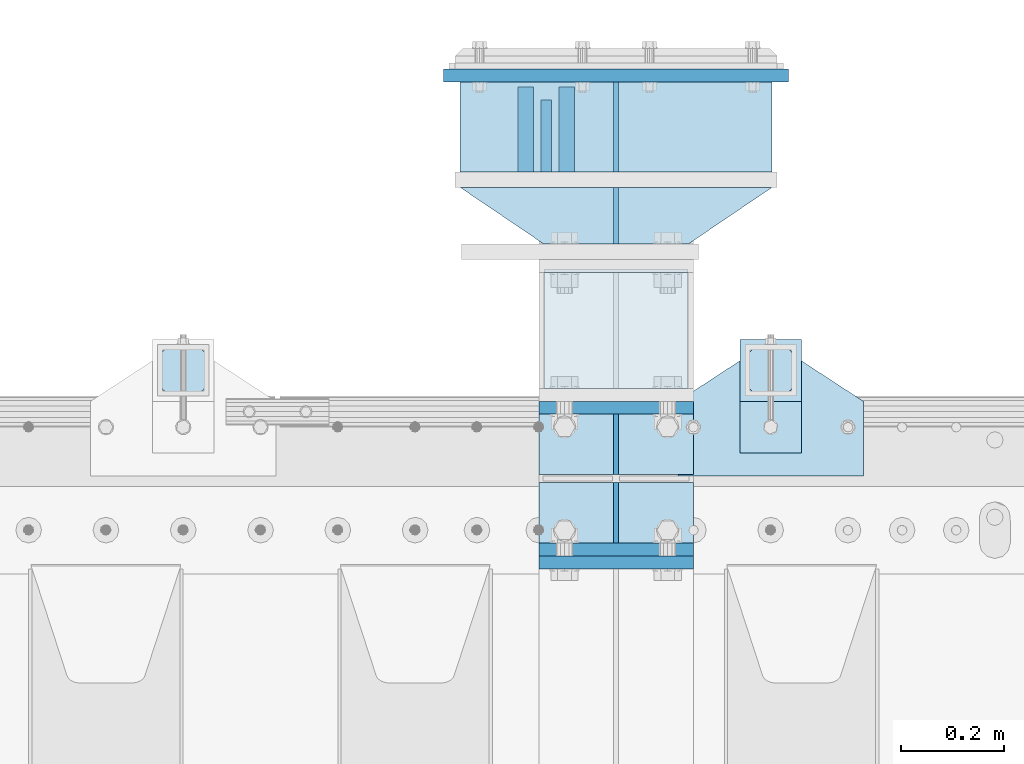
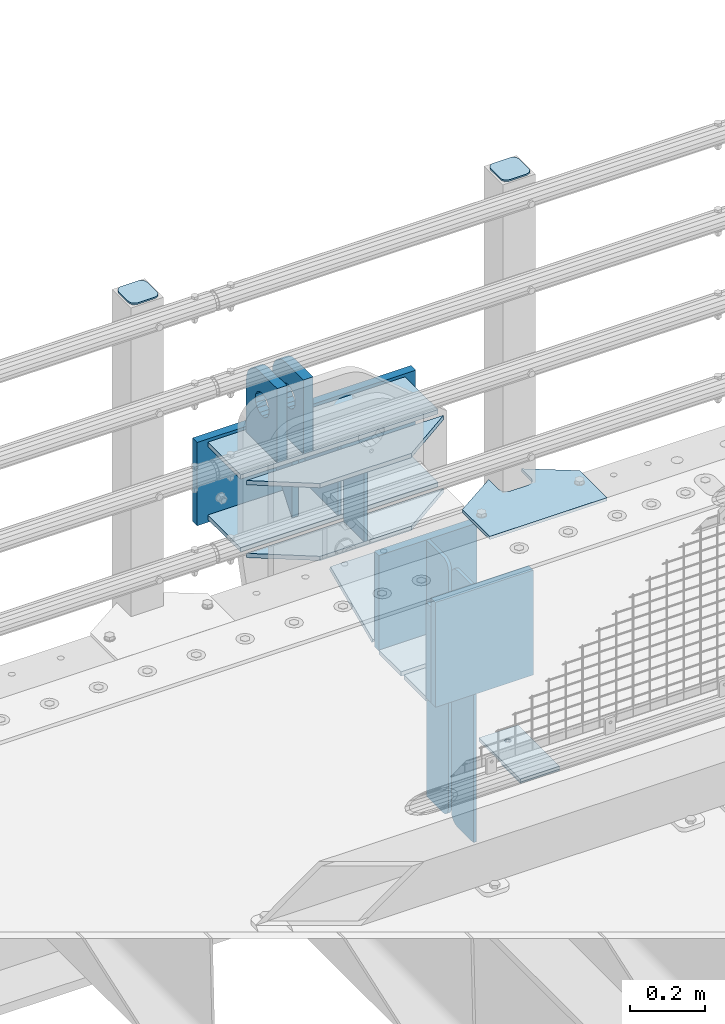
# One storey, part 225 of 240: 25 plates.
"""IFC2X3 building model written with IfcOpenShell, lengths in millimetres."""

from ifc_helpers import new_model, si_unit, frame, origin_with_axes, place, context, subcontext, project, spatial, faceted_brep, material, type_object, element, save


model = new_model("IFC2X3")

# Units and contexts
model_context = context("Model", 3, precision=1e-05, world=origin_with_axes())
body_context = subcontext(model_context, "Body", "Model", "MODEL_VIEW")
ifc_project = project(units=[si_unit("LENGTHUNIT", "METRE", prefix="MILLI"), si_unit("AREAUNIT", "SQUARE_METRE"), si_unit("VOLUMEUNIT", "CUBIC_METRE"), si_unit("MASSUNIT", "GRAM", prefix="KILO"), si_unit("TIMEUNIT", "SECOND"), si_unit("PLANEANGLEUNIT", "RADIAN"), si_unit("SOLIDANGLEUNIT", "STERADIAN"), si_unit("THERMODYNAMICTEMPERATUREUNIT", "DEGREE_CELSIUS"), si_unit("LUMINOUSINTENSITYUNIT", "LUMEN")], contexts=[model_context])

# Site, building, storey
site_placement = place(None, origin_with_axes())
site = spatial("IfcSite", under=ifc_project, at=site_placement, CompositionType="ELEMENT")
building_placement = place(site_placement, origin_with_axes())
building = spatial("IfcBuilding", under=site, at=building_placement, Name="Standard", CompositionType="ELEMENT")
storey_placement = place(building_placement, origin_with_axes())
storey = spatial("IfcBuildingStorey", under=building, at=storey_placement, Name="Undefined", CompositionType="ELEMENT", Elevation=0.0)

# Plates
ifc_material_1 = material(Name="STEEL/S355N")
plate_type_1 = type_object("IfcPlateType", PredefinedType="NOTDEFINED")
plate_1_placement = place(storey_placement, frame((52704.5000000536, 36735.0000000104, -14.000018238301), z_axis=(0.0, 0.0, -1.0), x_axis=(0.0, -1.0, 0.0)))
element("IfcPlate", 1, at=plate_1_placement, inside=storey, type_object=plate_type_1, material=ifc_material_1, context=body_context, shape_type="Brep", body=[
    faceted_brep([(0.0, -10.0, 0.0), (140.0, -10.0, 180.0), (140.0, 10.0, 180.0), (0.0, 10.0, 0.0), (140.0, -10.0, -1.81898940354586e-12), (140.0, 10.0, -1.81898940354586e-12)], [[[0, 1, 2, 3]], [[1, 4, 5, 2]], [[4, 0, 3, 5]], [[5, 3, 2]], [[4, 1, 0]]]),
])
plate_type_2 = type_object("IfcPlateType", PredefinedType="NOTDEFINED")
plate_2_placement = place(storey_placement, frame((52744.5000000519, 36595.0000000103, -1.8238333723275e-05), z_axis=(0.0, 1.0, 0.0), x_axis=(0.0, 0.0, 1.0)))
element("IfcPlate", 2, at=plate_2_placement, inside=storey, type_object=plate_type_2, material=ifc_material_1, context=body_context, shape_type="Brep", body=[
    faceted_brep([(125.840713002475, 15.0000005560505, 114.183542552877), (125.840713002475, -14.9999994439495, 114.183542852879), (113.837049096081, -14.9999995241524, 106.16295105387), (113.837049096081, 15.0000004758476, 106.162950753867), (105.816457297066, -14.9999996441911, 94.1592871474713), (105.816457297066, 15.0000003558089, 94.159286847469), (102.999999999984, -14.9999997857813, 80.0000001499648), (102.999999999984, 15.0000002142187, 79.9999998499625), (105.816457297066, -14.9999999273787, 65.8407131524582), (105.816457297066, 15.0000000726213, 65.8407128524559), (113.837049096081, -15.0000000474101, 53.8370492460599), (113.837049096081, 14.9999999525899, 53.8370489460576), (125.840713002475, -15.0000001276203, 45.8164574470502), (125.840713002475, 14.9999998723797, 45.8164571470479), (139.999999999984, -15.0000001557783, 43.0000001499648), (139.999999999984, 14.9999998442217, 42.9999998499625), (154.159286997492, -15.0000001276203, 45.8164574470502), (154.159286997492, 14.9999998723797, 45.8164571470479), (166.162950903886, -15.0000000474101, 53.8370492460599), (166.162950903886, 14.9999999525899, 53.8370489460576), (174.183542702901, -14.9999999273787, 65.8407131524582), (174.183542702901, 15.0000000726213, 65.8407128524559), (176.999999999984, -14.9999997857813, 80.0000001499648), (176.999999999984, 15.0000002142187, 79.9999998499625), (174.183542702901, -14.9999996441911, 94.1592871474713), (174.183542702901, 15.0000003558089, 94.159286847469), (166.162950903886, -14.9999995241524, 106.16295105387), (166.162950903886, 15.0000004758476, 106.162950753867), (154.159286997492, -14.9999994439495, 114.183542852879), (154.159286997492, 15.0000005560505, 114.183542552877), (139.999999999984, -14.9999994157915, 117.000000149965), (139.999999999984, 15.0000005842085, 116.999999849962), (-1.40620068123098e-06, -14.9999999999927, 165.000000000007), (170.002837349484, -14.9999999999927, 164.997157401471), (170.002837349484, 15.0000000000073, 164.997157401463), (-1.40620068123098e-06, 15.0000000000073, 165.0), (188.120138118986, -14.9999999999927, 162.611660295071), (188.120138118986, 15.0000000000073, 162.611660295064), (205.002693976271, -14.9999999999927, 155.618342674454), (205.002693976271, 15.0000000000073, 155.618342674454), (219.499985670386, -14.9999999999927, 144.493787979867), (219.499985670386, 15.0000000000073, 144.493787979867), (230.624045898169, -14.9999999999927, 129.996116868075), (230.624045898169, 15.0000000000073, 129.996116868067), (237.616787699976, -14.9999999999927, 113.113322498939), (237.616787699976, 15.0000000000073, 113.113322498939), (240.001666876698, -15.0, 94.9959403776302), (240.001666876698, 15.0, 94.9959403776229), (240.000015258789, -14.9999999999927, -2.03726813197136e-10), (240.000015258789, 15.0000000000073, -2.03726813197136e-10), (0.0, -15.0, 0.0), (0.0, 15.0, 0.0)], [[[0, 1, 2, 3]], [[3, 2, 4, 5]], [[5, 4, 6, 7]], [[7, 6, 8, 9]], [[9, 8, 10, 11]], [[11, 10, 12, 13]], [[13, 12, 14, 15]], [[15, 14, 16, 17]], [[17, 16, 18, 19]], [[19, 18, 20, 21]], [[21, 20, 22, 23]], [[23, 22, 24, 25]], [[25, 24, 26, 27]], [[27, 26, 28, 29]], [[29, 28, 30, 31]], [[31, 30, 1, 0]], [[32, 33, 34, 35]], [[33, 36, 37, 34]], [[36, 38, 39, 37]], [[38, 40, 41, 39]], [[40, 42, 43, 41]], [[42, 44, 45, 43]], [[44, 46, 47, 45]], [[46, 48, 49, 47]], [[48, 50, 51, 49]], [[34, 37, 39, 41, 43, 45, 47, 49, 51, 35], [3, 5, 7, 9, 11, 13, 15, 17, 19, 21, 23, 25, 27, 29, 31, 0]], [[50, 32, 35, 51]], [[48, 46, 44, 42, 40, 38, 36, 33, 32, 50], [26, 24, 22, 20, 18, 16, 14, 12, 10, 8, 6, 4, 2, 1, 30, 28]]]),
])
plate_3_placement = place(storey_placement, frame((52664.4999994678, 36595.0000000104, -1.82383118954021e-05), z_axis=(0.0, 1.0, 0.0), x_axis=(0.0, 0.0, 1.0)))
element("IfcPlate", 3, at=plate_3_placement, inside=storey, type_object=plate_type_2, material=ifc_material_1, context=body_context, shape_type="Brep", body=[
    faceted_brep([(125.840713002475, 15.0000005560505, 114.183542552877), (125.840713002475, -14.9999994439495, 114.183542852879), (113.837049096081, -14.9999995241524, 106.16295105387), (113.837049096081, 15.0000004758476, 106.162950753867), (105.816457297066, -14.9999996441911, 94.1592871474713), (105.816457297066, 15.0000003558089, 94.159286847469), (102.999999999984, -14.9999997857813, 80.0000001499648), (102.999999999984, 15.0000002142187, 79.9999998499625), (105.816457297066, -14.9999999273787, 65.8407131524582), (105.816457297066, 15.0000000726213, 65.8407128524559), (113.837049096081, -15.0000000474101, 53.8370492460599), (113.837049096081, 14.9999999525899, 53.8370489460576), (125.840713002475, -15.0000001276203, 45.8164574470502), (125.840713002475, 14.9999998723797, 45.8164571470479), (139.999999999984, -15.0000001557783, 43.0000001499648), (139.999999999984, 14.9999998442217, 42.9999998499625), (154.159286997492, -15.0000001276203, 45.8164574470502), (154.159286997492, 14.9999998723797, 45.8164571470479), (166.162950903886, -15.0000000474101, 53.8370492460599), (166.162950903886, 14.9999999525899, 53.8370489460576), (174.183542702901, -14.9999999273787, 65.8407131524582), (174.183542702901, 15.0000000726213, 65.8407128524559), (176.999999999984, -14.9999997857813, 80.0000001499648), (176.999999999984, 15.0000002142187, 79.9999998499625), (174.183542702901, -14.9999996441911, 94.1592871474713), (174.183542702901, 15.0000003558089, 94.159286847469), (166.162950903886, -14.9999995241524, 106.16295105387), (166.162950903886, 15.0000004758476, 106.162950753867), (154.159286997492, -14.9999994439495, 114.183542852879), (154.159286997492, 15.0000005560505, 114.183542552877), (139.999999999984, -14.9999994157915, 117.000000149965), (139.999999999984, 15.0000005842085, 116.999999849962), (-1.40620068123098e-06, -14.9999999999927, 165.000000000007), (170.0, -14.9999999999927, 165.0), (170.0, 15.0000000000073, 165.0), (-1.40620068123098e-06, 15.0000000000073, 165.0), (188.117333157176, -14.9999999999927, 162.614807840233), (188.117333157176, 15.0000000000073, 162.614807840233), (205.0, -14.9999999999927, 155.621778264911), (205.0, 15.0000000000073, 155.621778264911), (219.497474683058, -14.9999999999927, 144.497474683056), (219.497474683058, 15.0000000000073, 144.497474683063), (230.621778264911, -14.9999999999927, 130.0), (230.621778264911, 15.0000000000073, 130.0), (237.614807840235, -14.9999999999927, 113.117333157177), (237.614807840235, 15.0000000000073, 113.117333157177), (240.0, -14.9999999999927, 95.0), (240.0, 15.0000000000073, 95.0), (240.000015258789, -14.9999999999927, -2.03726813197136e-10), (240.000015258789, 15.0000000000073, -2.03726813197136e-10), (0.0, -15.0, 0.0), (0.0, 15.0, 0.0)], [[[0, 1, 2, 3]], [[3, 2, 4, 5]], [[5, 4, 6, 7]], [[7, 6, 8, 9]], [[9, 8, 10, 11]], [[11, 10, 12, 13]], [[13, 12, 14, 15]], [[15, 14, 16, 17]], [[17, 16, 18, 19]], [[19, 18, 20, 21]], [[21, 20, 22, 23]], [[23, 22, 24, 25]], [[25, 24, 26, 27]], [[27, 26, 28, 29]], [[29, 28, 30, 31]], [[31, 30, 1, 0]], [[32, 33, 34, 35]], [[33, 36, 37, 34]], [[36, 38, 39, 37]], [[38, 40, 41, 39]], [[40, 42, 43, 41]], [[42, 44, 45, 43]], [[44, 46, 47, 45]], [[46, 48, 49, 47]], [[48, 50, 51, 49]], [[34, 37, 39, 41, 43, 45, 47, 49, 51, 35], [3, 5, 7, 9, 11, 13, 15, 17, 19, 21, 23, 25, 27, 29, 31, 0]], [[50, 32, 35, 51]], [[48, 46, 44, 42, 40, 38, 36, 33, 32, 50], [26, 24, 22, 20, 18, 16, 14, 12, 10, 8, 6, 4, 2, 1, 30, 28]]]),
])
plate_type_3 = type_object("IfcPlateType", PredefinedType="NOTDEFINED")
plate_4_placement = place(storey_placement, frame((52690.0, 35837.5, -340.000000000044), z_axis=(0.0, 0.0, 1.0), x_axis=(1.0, 0.0, 0.0)))
element("IfcPlate", 4, at=plate_4_placement, inside=storey, type_object=plate_type_3, material=ifc_material_1, context=body_context, shape_type="Brep", body=[
    faceted_brep([(0.0, -12.5, 0.0), (9.31322574615479e-10, -12.5, 340.0), (9.31322574615479e-10, 12.5, 340.0), (0.0, 12.5, 0.0), (300.0, -12.5, 340.0), (300.0, 12.5, 340.0), (300.0, -12.5, 0.0), (300.0, 12.5, 0.0)], [[[0, 1, 2, 3]], [[1, 4, 5, 2]], [[4, 6, 7, 5]], [[6, 0, 3, 7]], [[5, 7, 3, 2]], [[6, 4, 1, 0]]]),
])
for number, where, z_axis, x_axis in (
    (5, (52690.0, 36137.5, -340.0), (0.0, 0.0, 1.0), (1.0, 0.0, 0.0)),
    (6, (52690.0, 35862.5, -340.0), (0.0, 0.0, 1.0), (1.0, 0.0, 0.0)),
):
    element("IfcPlate", number, at=place(storey_placement, frame(where, z_axis=z_axis, x_axis=x_axis)), inside=storey, type_object=plate_type_3, material=ifc_material_1, context=body_context, shape_type="Brep", body=[
        faceted_brep([(0.0, -12.5, 0.0), (0.0, -12.5, 310.0), (0.0, 12.5, 310.0), (0.0, 12.5, 0.0), (300.0, -12.5, 310.0), (300.0, 12.5, 310.0), (300.0, -12.5, 0.0), (300.0, 12.5, 0.0)], [[[0, 1, 2, 3]], [[1, 4, 5, 2]], [[4, 6, 7, 5]], [[6, 0, 3, 7]], [[5, 7, 3, 2]], [[6, 4, 1, 0]]]),
    ])
plate_type_4 = type_object("IfcPlateType", PredefinedType="NOTDEFINED")
for number, where, z_axis, x_axis in (
    (7, (52690.0, 35992.0, -343.0), (0.0, -1.0, 0.0), (1.0, 0.0, 0.0)),
    (8, (52690.0, 36008.0, -343.0), (0.0, 1.0, 0.0), (1.0, 0.0, 0.0)),
):
    element("IfcPlate", number, at=place(storey_placement, frame(where, z_axis=z_axis, x_axis=x_axis)), inside=storey, type_object=plate_type_4, material=ifc_material_1, context=body_context, shape_type="Brep", body=[
        faceted_brep([(0.0, -7.0, 0.0), (0.0, -7.0, 117.0), (0.0, 7.0, 117.0), (0.0, 7.0, 0.0), (300.0, -7.0, 117.0), (300.0, 7.0, 117.0), (300.0, -7.0, 0.0), (300.0, 7.0, 0.0)], [[[0, 1, 2, 3]], [[1, 4, 5, 2]], [[4, 6, 7, 5]], [[6, 0, 3, 7]], [[5, 7, 3, 2]], [[6, 4, 1, 0]]]),
    ])
plate_type_5 = type_object("IfcPlateType", PredefinedType="NOTDEFINED")
for number, where, z_axis, x_axis in (
    (9, (52840.0, 36008.0, -30.0), (0.0, 0.0, -1.0), (0.0, 1.0, 0.0)),
    (10, (52840.0, 35992.0, -30.0), (0.0, 0.0, -1.0), (0.0, -1.0, 0.0)),
):
    element("IfcPlate", number, at=place(storey_placement, frame(where, z_axis=z_axis, x_axis=x_axis)), inside=storey, type_object=plate_type_5, material=ifc_material_1, context=body_context, shape_type="Brep", body=[
        faceted_brep([(0.0, -5.0, 30.0), (0.0, -5.0, 306.0), (0.0, 5.0, 306.0), (0.0, 5.0, 30.0), (117.0, -5.0, 306.0), (117.0, 5.0, 306.0), (117.0, -5.0, 0.0), (117.0, 5.0, 0.0), (30.0, -5.0, 0.0), (30.0, 5.0, 0.0), (24.7905546699913, -5.0, 0.455767409633758), (24.7905546699913, 5.0, 0.455767409633758), (19.7393957002278, -5.0, 1.80922137642275), (19.7393957002278, 5.0, 1.80922137642275), (15.0, -5.0, 4.01923788646684), (15.0, 5.0, 4.01923788646684), (10.7163717094008, -5.0, 7.01866670643066), (10.7163717094008, 5.0, 7.01866670643066), (7.01866670643358, -5.0, 10.7163717094038), (7.01866670643358, 5.0, 10.7163717094038), (4.01923788646673, -5.0, 15.0), (4.01923788646673, 5.0, 15.0), (1.80922137642483, -5.0, 19.7393957002299), (1.80922137642483, 5.0, 19.7393957002299), (0.455767409635882, -5.0, 24.7905546699921), (0.455767409635882, 5.0, 24.7905546699921)], [[[0, 1, 2, 3]], [[1, 4, 5, 2]], [[4, 6, 7, 5]], [[6, 8, 9, 7]], [[8, 10, 11, 9]], [[10, 12, 13, 11]], [[12, 14, 15, 13]], [[14, 16, 17, 15]], [[16, 18, 19, 17]], [[18, 20, 21, 19]], [[20, 22, 23, 21]], [[22, 24, 25, 23]], [[24, 0, 3, 25]], [[5, 7, 9, 11, 13, 15, 17, 19, 21, 23, 25, 3, 2]], [[24, 22, 20, 18, 16, 14, 12, 10, 8, 6, 4, 1, 0]]]),
    ])
for number, where, z_axis, x_axis in (
    (11, (52840.0, 35992.0, -350.0), (0.0, 0.0, -1.0), (0.0, -1.0, 0.0)),
    (12, (52840.0, 36008.0, -350.0), (0.0, 0.0, -1.0), (0.0, 1.0, 0.0)),
):
    element("IfcPlate", number, at=place(storey_placement, frame(where, z_axis=z_axis, x_axis=x_axis)), inside=storey, type_object=plate_type_5, material=ifc_material_1, context=body_context, shape_type="Brep", body=[
        faceted_brep([(0.0, -5.0, 0.0), (0.0, -5.0, 480.0), (0.0, 5.0, 480.0), (0.0, 5.0, 0.0), (0.455767409635882, -5.0, 485.209445330008), (0.455767409635882, 5.0, 485.209445330008), (1.80922137642483, -5.0, 490.26060429977), (1.80922137642483, 5.0, 490.26060429977), (4.01923788646673, -5.0, 495.0), (4.01923788646673, 5.0, 495.0), (7.01866670643358, -5.0, 499.283628290596), (7.01866670643358, 5.0, 499.283628290596), (10.7163717094008, -5.0, 502.981333293569), (10.7163717094008, 5.0, 502.981333293569), (15.0, -5.0, 505.980762113533), (15.0, 5.0, 505.980762113533), (19.7393957002278, -5.0, 508.190778623577), (19.7393957002278, 5.0, 508.190778623577), (24.7905546699913, -5.0, 509.544232590366), (24.7905546699913, 5.0, 509.544232590366), (30.0, -5.0, 510.0), (30.0, 5.0, 510.0), (117.0, -5.0, 510.0), (117.0, 5.0, 510.0), (117.0, -5.0, 0.0), (117.0, 5.0, 0.0)], [[[0, 1, 2, 3]], [[1, 4, 5, 2]], [[4, 6, 7, 5]], [[6, 8, 9, 7]], [[8, 10, 11, 9]], [[10, 12, 13, 11]], [[12, 14, 15, 13]], [[14, 16, 17, 15]], [[16, 18, 19, 17]], [[18, 20, 21, 19]], [[20, 22, 23, 21]], [[22, 24, 25, 23]], [[24, 0, 3, 25]], [[5, 7, 9, 11, 13, 15, 17, 19, 21, 23, 25, 3, 2]], [[24, 22, 20, 18, 16, 14, 12, 10, 8, 6, 4, 1, 0]]]),
    ])
ifc_material_2 = material(Name="STEEL/S355J2")
plate_type_6 = type_object("IfcPlateType", PredefinedType="NOTDEFINED")
plate_5_placement = place(storey_placement, frame((52960.0, 36005.0, 5.00000000004911), z_axis=(0.0, 1.0, 0.0), x_axis=(1.0, 0.0, 0.0)))
element("IfcPlate", 13, at=plate_5_placement, inside=storey, type_object=plate_type_6, material=ifc_material_2, context=body_context, shape_type="Brep", body=[
    faceted_brep([(0.0, -5.0, 0.0), (2.31396552408114e-06, -5.0, 145.0), (2.31396552408114e-06, 5.0, 145.0), (0.0, 5.0, 0.0), (130.0, -5.0, 230.0), (130.0, 5.0, 230.0), (130.0, -5.0, 180.0), (130.0, 5.0, 180.0), (130.48036798992, -5.0, 175.122741949599), (130.48036798992, 5.0, 175.122741949599), (131.903011687216, -5.0, 170.432914190875), (131.903011687216, 5.0, 170.432914190875), (134.213259692435, -5.0, 166.110744174512), (134.213259692435, 5.0, 166.110744174512), (137.322330470335, -5.0, 162.322330470335), (137.322330470335, 5.0, 162.322330470335), (141.110744174512, -5.0, 159.213259692435), (141.110744174512, 5.0, 159.213259692435), (145.432914190875, -5.0, 156.903011687216), (145.432914190875, 5.0, 156.903011687216), (150.122741949599, -5.0, 155.48036798992), (150.122741949599, 5.0, 155.48036798992), (155.0, -5.0, 155.0), (155.0, 5.0, 155.0), (205.0, -5.0, 155.0), (205.0, 5.0, 155.0), (209.877258050401, -5.0, 155.48036798992), (209.877258050401, 5.0, 155.48036798992), (214.567085809125, -5.0, 156.903011687216), (214.567085809125, 5.0, 156.903011687216), (218.889255825488, -5.0, 159.213259692435), (218.889255825488, 5.0, 159.213259692435), (222.677669529665, -5.0, 162.322330470335), (222.677669529665, 5.0, 162.322330470335), (225.786740307565, -5.0, 166.110744174512), (225.786740307565, 5.0, 166.110744174512), (228.096988312784, -5.0, 170.432914190875), (228.096988312784, 5.0, 170.432914190875), (229.51963201008, -5.0, 175.122741949599), (229.51963201008, 5.0, 175.122741949599), (230.0, -5.0, 180.0), (230.0, 5.0, 180.0), (230.0, -5.0, 230.0), (230.0, 5.0, 230.0), (360.0, -5.0, 145.0), (360.0, 5.0, 145.0), (360.0, -5.0, -7.27595761418343e-12), (360.0, 5.0, -7.27595761418343e-12)], [[[0, 1, 2, 3]], [[1, 4, 5, 2]], [[4, 6, 7, 5]], [[6, 8, 9, 7]], [[8, 10, 11, 9]], [[10, 12, 13, 11]], [[12, 14, 15, 13]], [[14, 16, 17, 15]], [[16, 18, 19, 17]], [[18, 20, 21, 19]], [[20, 22, 23, 21]], [[22, 24, 25, 23]], [[24, 26, 27, 25]], [[26, 28, 29, 27]], [[28, 30, 31, 29]], [[30, 32, 33, 31]], [[32, 34, 35, 33]], [[34, 36, 37, 35]], [[36, 38, 39, 37]], [[38, 40, 41, 39]], [[40, 42, 43, 41]], [[42, 44, 45, 43]], [[44, 46, 47, 45]], [[46, 0, 3, 47]], [[5, 7, 9, 11, 13, 15, 17, 19, 21, 23, 25, 27, 29, 31, 33, 35, 37, 39, 41, 43, 45, 47, 3, 2]], [[46, 44, 42, 40, 38, 36, 34, 32, 30, 28, 26, 24, 22, 20, 18, 16, 14, 12, 10, 8, 6, 4, 1, 0]]]),
])
plate_type_7 = type_object("IfcPlateType", PredefinedType="NOTDEFINED")
plate_6_placement = place(storey_placement, frame((53080.0000000001, 36050.0000000002, -850.000000000002), z_axis=(0.0, 1.0, 0.0), x_axis=(1.0, 0.0, 0.0)))
element("IfcPlate", 14, at=plate_6_placement, inside=storey, type_object=plate_type_7, material=ifc_material_2, context=body_context, shape_type="Brep", body=[
    faceted_brep([(66.3639610305399, -5.0, 163.636038969111), (66.3639610305399, 5.0, 163.636038969111), (59.9999999998618, 5.0, 160.999999999789), (59.9999999998618, -5.0, 160.999999999789), (53.6360389691836, 5.0, 163.636038969111), (53.6360389691836, -5.0, 163.636038969111), (50.9999999998618, 5.0, 169.999999999789), (50.9999999998618, -5.0, 169.999999999789), (53.6360389691836, 5.0, 176.363961030467), (53.6360389691836, -5.0, 176.363961030467), (59.9999999998618, 5.0, 178.999999999789), (59.9999999998618, -5.0, 178.999999999789), (66.3639610305399, 5.0, 176.363961030467), (66.3639610305399, -5.0, 176.363961030467), (68.9999999998618, 5.0, 169.999999999789), (68.9999999998618, -5.0, 169.999999999789), (120.0, -5.0, 0.0), (120.0, -5.0, 220.0), (0.0, -5.0, 220.0), (0.0, -5.0, 0.0), (0.0, 5.0, 0.0), (120.0, 5.0, 0.0), (120.0, 5.0, 220.0), (0.0, 5.0, 220.0)], [[[0, 1, 2, 3]], [[3, 2, 4, 5]], [[5, 4, 6, 7]], [[7, 6, 8, 9]], [[9, 8, 10, 11]], [[11, 10, 12, 13]], [[13, 12, 14, 15]], [[15, 14, 1, 0]], [[16, 17, 18, 19], [3, 5, 7, 9, 11, 13, 15, 0]], [[16, 19, 20, 21]], [[17, 16, 21, 22]], [[18, 17, 22, 23]], [[19, 18, 23, 20]], [[22, 21, 20, 23], [10, 8, 6, 4, 2, 1, 14, 12]]]),
])
plate_type_8 = type_object("IfcPlateType", PredefinedType="NOTDEFINED")
plate_7_placement = place(storey_placement, frame((53184.0000000001, 36166.0000000002, 1012.50000000001), z_axis=(0.0, 1.0, 0.0), x_axis=(-1.0, 0.0, 0.0)))
element("IfcPlate", 15, at=plate_7_placement, inside=storey, type_object=plate_type_8, material=ifc_material_2, context=body_context, shape_type="Brep", body=[
    faceted_brep([(0.0, -2.5, 19.0), (0.0, -2.5, 69.0), (0.0, 2.5, 69.0), (0.0, 2.5, 19.0), (0.476369668547704, -2.5, 73.2278977451715), (0.476369668547704, 2.5, 73.2278977451715), (1.88159150985302, -2.5, 77.2437910432345), (1.88159150985302, 2.5, 77.2437910432345), (4.14520183311106, -2.5, 80.8463062353185), (4.14520183311106, 2.5, 80.8463062353185), (7.15369376468152, -2.5, 83.8547981668889), (7.15369376468152, 2.5, 83.8547981668889), (10.7562089567655, -2.5, 86.118408490147), (10.7562089567655, 2.5, 86.118408490147), (14.7721022548285, -2.5, 87.5236303314523), (14.7721022548285, 2.5, 87.5236303314523), (19.0, -2.5, 88.0), (19.0, 2.5, 88.0), (69.0, -2.5, 88.0), (69.0, 2.5, 88.0), (73.2278977451715, -2.5, 87.5236303314523), (73.2278977451715, 2.5, 87.5236303314523), (77.2437910432345, -2.5, 86.118408490147), (77.2437910432345, 2.5, 86.118408490147), (80.8463062353185, -2.5, 83.8547981668889), (80.8463062353185, 2.5, 83.8547981668889), (83.8547981668889, -2.5, 80.8463062353185), (83.8547981668889, 2.5, 80.8463062353185), (86.118408490147, -2.5, 77.2437910432345), (86.118408490147, 2.5, 77.2437910432345), (87.5236303314523, -2.5, 73.2278977451715), (87.5236303314523, 2.5, 73.2278977451715), (88.0, -2.5, 69.0), (88.0, 2.5, 69.0), (88.0, -2.5, 19.0), (88.0, 2.5, 19.0), (87.5236303314523, -2.5, 14.7721022548285), (87.5236303314523, 2.5, 14.7721022548285), (86.118408490147, -2.5, 10.7562089567655), (86.118408490147, 2.5, 10.7562089567655), (83.8547981668889, -2.5, 7.15369376468152), (83.8547981668889, 2.5, 7.15369376468152), (80.8463062353185, -2.5, 4.14520183311106), (80.8463062353185, 2.5, 4.14520183311106), (77.2437910432345, -2.5, 1.88159150985302), (77.2437910432345, 2.5, 1.88159150985302), (73.2278977451715, -2.5, 0.476369668547704), (73.2278977451715, 2.5, 0.476369668547704), (69.0, -2.5, 0.0), (69.0, 2.5, 0.0), (19.0, -2.5, 0.0), (19.0, 2.5, 0.0), (14.7721022548285, -2.5, 0.476369668547704), (14.7721022548285, 2.5, 0.476369668547704), (10.7562089567655, -2.5, 1.88159150985302), (10.7562089567655, 2.5, 1.88159150985302), (7.15369376468152, -2.5, 4.14520183311106), (7.15369376468152, 2.5, 4.14520183311106), (4.14520183311106, -2.5, 7.15369376468152), (4.14520183311106, 2.5, 7.15369376468152), (1.88159150985302, -2.5, 10.7562089567655), (1.88159150985302, 2.5, 10.7562089567655), (0.476369668547704, -2.5, 14.7721022548285), (0.476369668547704, 2.5, 14.7721022548285)], [[[0, 1, 2, 3]], [[1, 4, 5, 2]], [[4, 6, 7, 5]], [[6, 8, 9, 7]], [[8, 10, 11, 9]], [[10, 12, 13, 11]], [[12, 14, 15, 13]], [[14, 16, 17, 15]], [[16, 18, 19, 17]], [[18, 20, 21, 19]], [[20, 22, 23, 21]], [[22, 24, 25, 23]], [[24, 26, 27, 25]], [[26, 28, 29, 27]], [[28, 30, 31, 29]], [[30, 32, 33, 31]], [[32, 34, 35, 33]], [[34, 36, 37, 35]], [[36, 38, 39, 37]], [[38, 40, 41, 39]], [[40, 42, 43, 41]], [[42, 44, 45, 43]], [[44, 46, 47, 45]], [[46, 48, 49, 47]], [[48, 50, 51, 49]], [[50, 52, 53, 51]], [[52, 54, 55, 53]], [[54, 56, 57, 55]], [[56, 58, 59, 57]], [[58, 60, 61, 59]], [[60, 62, 63, 61]], [[62, 0, 3, 63]], [[5, 7, 9, 11, 13, 15, 17, 19, 21, 23, 25, 27, 29, 31, 33, 35, 37, 39, 41, 43, 45, 47, 49, 51, 53, 55, 57, 59, 61, 63, 3, 2]], [[62, 60, 58, 56, 54, 52, 50, 48, 46, 44, 42, 40, 38, 36, 34, 32, 30, 28, 26, 24, 22, 20, 18, 16, 14, 12, 10, 8, 6, 4, 1, 0]]]),
])
plate_8_placement = place(storey_placement, frame((52044.0000000001, 36166.0000000002, 1012.50000000001), z_axis=(0.0, 1.0, 0.0), x_axis=(-1.0, 0.0, 0.0)))
element("IfcPlate", 16, at=plate_8_placement, inside=storey, type_object=plate_type_8, material=ifc_material_2, context=body_context, shape_type="Brep", body=[
    faceted_brep([(0.0, -2.5, 19.0), (0.0, -2.5, 69.0), (0.0, 2.5, 69.0), (0.0, 2.5, 19.0), (0.476369668547704, -2.5, 73.2278977451715), (0.476369668547704, 2.5, 73.2278977451715), (1.88159150985302, -2.5, 77.2437910432345), (1.88159150985302, 2.5, 77.2437910432345), (4.14520183311106, -2.5, 80.8463062353185), (4.14520183311106, 2.5, 80.8463062353185), (7.15369376468152, -2.5, 83.8547981668889), (7.15369376468152, 2.5, 83.8547981668889), (10.7562089567655, -2.5, 86.118408490147), (10.7562089567655, 2.5, 86.118408490147), (14.7721022548285, -2.5, 87.5236303314523), (14.7721022548285, 2.5, 87.5236303314523), (19.0, -2.5, 88.0), (19.0, 2.5, 88.0), (69.0, -2.5, 88.0), (69.0, 2.5, 88.0), (73.2278977451715, -2.5, 87.5236303314523), (73.2278977451715, 2.5, 87.5236303314523), (77.2437910432345, -2.5, 86.118408490147), (77.2437910432345, 2.5, 86.118408490147), (80.8463062353185, -2.5, 83.8547981668889), (80.8463062353185, 2.5, 83.8547981668889), (83.8547981668889, -2.5, 80.8463062353185), (83.8547981668889, 2.5, 80.8463062353185), (86.118408490147, -2.5, 77.2437910432345), (86.118408490147, 2.5, 77.2437910432345), (87.5236303314523, -2.5, 73.2278977451715), (87.5236303314523, 2.5, 73.2278977451715), (88.0, -2.5, 69.0), (88.0, 2.5, 69.0), (88.0, -2.5, 19.0), (88.0, 2.5, 19.0), (87.5236303314523, -2.5, 14.7721022548285), (87.5236303314523, 2.5, 14.7721022548285), (86.118408490147, -2.5, 10.7562089567655), (86.118408490147, 2.5, 10.7562089567655), (83.8547981668889, -2.5, 7.15369376468152), (83.8547981668889, 2.5, 7.15369376468152), (80.8463062353185, -2.5, 4.14520183311106), (80.8463062353185, 2.5, 4.14520183311106), (77.2437910432345, -2.5, 1.88159150985302), (77.2437910432345, 2.5, 1.88159150985302), (73.2278977451715, -2.5, 0.476369668547704), (73.2278977451715, 2.5, 0.476369668547704), (69.0, -2.5, 0.0), (69.0, 2.5, 0.0), (19.0, -2.5, 0.0), (19.0, 2.5, 0.0), (14.7721022548285, -2.5, 0.476369668547704), (14.7721022548285, 2.5, 0.476369668547704), (10.7562089567655, -2.5, 1.88159150985302), (10.7562089567655, 2.5, 1.88159150985302), (7.15369376468152, -2.5, 4.14520183311106), (7.15369376468152, 2.5, 4.14520183311106), (4.14520183311106, -2.5, 7.15369376468152), (4.14520183311106, 2.5, 7.15369376468152), (1.88159150985302, -2.5, 10.7562089567655), (1.88159150985302, 2.5, 10.7562089567655), (0.476369668547704, -2.5, 14.7721022548285), (0.476369668547704, 2.5, 14.7721022548285)], [[[0, 1, 2, 3]], [[1, 4, 5, 2]], [[4, 6, 7, 5]], [[6, 8, 9, 7]], [[8, 10, 11, 9]], [[10, 12, 13, 11]], [[12, 14, 15, 13]], [[14, 16, 17, 15]], [[16, 18, 19, 17]], [[18, 20, 21, 19]], [[20, 22, 23, 21]], [[22, 24, 25, 23]], [[24, 26, 27, 25]], [[26, 28, 29, 27]], [[28, 30, 31, 29]], [[30, 32, 33, 31]], [[32, 34, 35, 33]], [[34, 36, 37, 35]], [[36, 38, 39, 37]], [[38, 40, 41, 39]], [[40, 42, 43, 41]], [[42, 44, 45, 43]], [[44, 46, 47, 45]], [[46, 48, 49, 47]], [[48, 50, 51, 49]], [[50, 52, 53, 51]], [[52, 54, 55, 53]], [[54, 56, 57, 55]], [[56, 58, 59, 57]], [[58, 60, 61, 59]], [[60, 62, 63, 61]], [[62, 0, 3, 63]], [[5, 7, 9, 11, 13, 15, 17, 19, 21, 23, 25, 27, 29, 31, 33, 35, 37, 39, 41, 43, 45, 47, 49, 51, 53, 55, 57, 59, 61, 63, 3, 2]], [[62, 60, 58, 56, 54, 52, 50, 48, 46, 44, 42, 40, 38, 36, 34, 32, 30, 28, 26, 24, 22, 20, 18, 16, 14, 12, 10, 8, 6, 4, 1, 0]]]),
])
plate_type_9 = type_object("IfcPlateType", PredefinedType="NOTDEFINED")
plate_9_placement = place(storey_placement, frame((53080.0000000001, 36050.0000000002, -857.500000000002), z_axis=(0.0, 1.0, 0.0), x_axis=(1.0, 0.0, 0.0)))
element("IfcPlate", 17, at=plate_9_placement, inside=storey, type_object=plate_type_9, material=ifc_material_2, context=body_context, shape_type="Brep", body=[
    faceted_brep([(0.0, -2.5, 0.0), (0.0, -2.5, 100.0), (0.0, 2.5, 100.0), (0.0, 2.5, 0.0), (120.0, -2.5, 100.0), (120.0, 2.5, 100.0), (120.0, -2.5, 0.0), (120.0, 2.5, 0.0)], [[[0, 1, 2, 3]], [[1, 4, 5, 2]], [[4, 6, 7, 5]], [[6, 0, 3, 7]], [[5, 7, 3, 2]], [[6, 4, 1, 0]]]),
])
ifc_material_3 = material()
plate_type_10 = type_object("IfcPlateType", PredefinedType="NOTDEFINED")
for number, where, z_axis, x_axis in (
    (18, (53142.5, 36595.0000000345, -243.000018222274), (0.0, 1.0, 0.0), (-1.0, 0.0, 0.0)),
    (19, (53142.5, 36595.0000000345, -7.00001822227398), (0.0, 1.0, 0.0), (-1.0, 0.0, 0.0)),
):
    element("IfcPlate", number, at=place(storey_placement, frame(where, z_axis=z_axis, x_axis=x_axis)), inside=storey, type_object=plate_type_10, material=ifc_material_3, context=body_context, shape_type="Brep", body=[
        faceted_brep([(0.0, -7.0, 0.0), (0.0, -7.0, 175.0), (0.0, 7.0, 175.0), (0.0, 7.0, 0.0), (605.0, -7.0, 175.0), (605.0, 7.0, 175.0), (605.0, -7.0, 0.0), (605.0, 7.0, 0.0)], [[[0, 1, 2, 3]], [[1, 4, 5, 2]], [[4, 6, 7, 5]], [[6, 0, 3, 7]], [[5, 7, 3, 2]], [[6, 4, 1, 0]]]),
    ])
plate_type_11 = type_object("IfcPlateType", PredefinedType="NOTDEFINED")
plate_10_placement = place(storey_placement, frame((52840.0, 36770.0000000345, -14.000018222274), z_axis=(0.0, 0.0, -1.0), x_axis=(0.0, -1.0, 0.0)))
element("IfcPlate", 20, at=plate_10_placement, inside=storey, type_object=plate_type_11, material=ifc_material_1, context=body_context, shape_type="Brep", body=[
    faceted_brep([(0.0, -5.0, 0.0), (0.0, -5.0, 222.0), (0.0, 5.0, 222.0), (0.0, 5.0, 0.0), (175.0, -5.0, 222.0), (175.0, 5.0, 222.0), (175.0, -5.0, 0.0), (175.0, 5.0, 0.0)], [[[0, 1, 2, 3]], [[1, 4, 5, 2]], [[4, 6, 7, 5]], [[6, 0, 3, 7]], [[5, 7, 3, 2]], [[6, 4, 1, 0]]]),
])
plate_type_12 = type_object("IfcPlateType", PredefinedType="NOTDEFINED")
plate_11_placement = place(storey_placement, frame((53175.0, 36782.5000000345, 9.99998177772602), z_axis=(0.0, 0.0, -1.0), x_axis=(-1.0, 0.0, 0.0)))
element("IfcPlate", 21, at=plate_11_placement, inside=storey, type_object=plate_type_12, material=ifc_material_1, context=body_context, shape_type="Brep", body=[
    faceted_brep([(0.0, -12.5, 0.0), (0.0, -12.5, 270.0), (0.0, 12.5, 270.0), (0.0, 12.5, 0.0), (670.0, -12.5, 270.0), (670.0, 12.5, 270.0), (670.0, -12.5, 0.0), (670.0, 12.5, 0.0)], [[[0, 1, 2, 3]], [[1, 4, 5, 2]], [[4, 6, 7, 5]], [[6, 0, 3, 7]], [[5, 7, 3, 2]], [[6, 4, 1, 0]]]),
])
plate_type_13 = type_object("IfcPlateType", PredefinedType="NOTDEFINED")
for number, where, z_axis, x_axis in (
    (22, (53142.5, 36565.0000000345, -7.00001822227398), (-0.560566412034008, 0.828109472050235, 0.0), (-0.828109472050229, -0.560566412034017, 0.0)),
    (23, (53142.5, 36565.0000000345, -243.000018222274), (-0.560566412034008, 0.828109472050235, 0.0), (-0.828109472050229, -0.560566412034017, 0.0)),
):
    element("IfcPlate", number, at=place(storey_placement, frame(where, z_axis=z_axis, x_axis=x_axis)), inside=storey, type_object=plate_type_13, material=ifc_material_1, context=body_context, shape_type="Brep", body=[
        faceted_brep([(0.0, -7.0, 0.0), (501.006225585945, -7.0, 339.142669677733), (501.006225585945, 7.0, 339.142669677733), (0.0, 7.0, 0.0), (428.100738525383, -7.0, 156.958602905272), (428.100738525383, 7.0, 156.958602905272), (196.230087280266, -7.0, -4.34624780609738e-10), (196.230087280266, 7.0, -4.34624780609738e-10)], [[[0, 1, 2, 3]], [[1, 4, 5, 2]], [[4, 6, 7, 5]], [[6, 0, 3, 7]], [[5, 7, 3, 2]], [[6, 4, 1, 0]]]),
    ])
plate_type_14 = type_object("IfcPlateType", PredefinedType="NOTDEFINED")
plate_12_placement = place(storey_placement, frame((52840.0, 36565.0000000345, -14.000018222274), z_axis=(0.0, 0.0, -1.0), x_axis=(0.0, -1.0, 0.0)))
element("IfcPlate", 24, at=plate_12_placement, inside=storey, type_object=plate_type_14, material=ifc_material_1, context=body_context, shape_type="Brep", body=[
    faceted_brep([(0.0, -5.0, 0.0), (0.0, -5.0, 222.0), (0.0, 5.0, 222.0), (0.0, 5.0, 0.0), (110.0, -5.0, 222.0), (110.0, 5.0, 222.0), (110.0, -5.0, 0.0), (110.0, 5.0, 0.0)], [[[0, 1, 2, 3]], [[1, 4, 5, 2]], [[4, 6, 7, 5]], [[6, 0, 3, 7]], [[5, 7, 3, 2]], [[6, 4, 1, 0]]]),
])
plate_type_15 = type_object("IfcPlateType", PredefinedType="NOTDEFINED")
plate_13_placement = place(storey_placement, frame((52700.0, 36177.8429692969, -342.396699062616), z_axis=(0.0, 0.913811548702731, 0.406138465867881), x_axis=(1.0, 0.0, 0.0)))
element("IfcPlate", 25, at=plate_13_placement, inside=storey, type_object=plate_type_15, material=ifc_material_1, context=body_context, shape_type="Brep", body=[
    faceted_brep([(0.0, -7.0, 0.0), (0.0, -7.0, 246.221450805664), (0.0, 7.0, 246.221450805664), (0.0, 7.0, 0.0), (280.0, -7.0, 246.221450805664), (280.0, 7.0, 246.221450805664), (280.0, -6.99999999999818, 0.0), (280.0, 7.0, 0.0)], [[[0, 1, 2, 3]], [[1, 4, 5, 2]], [[4, 6, 7, 5]], [[6, 0, 3, 7]], [[5, 7, 3, 2]], [[6, 4, 1, 0]]]),
])

save(model, "model.ifc")
